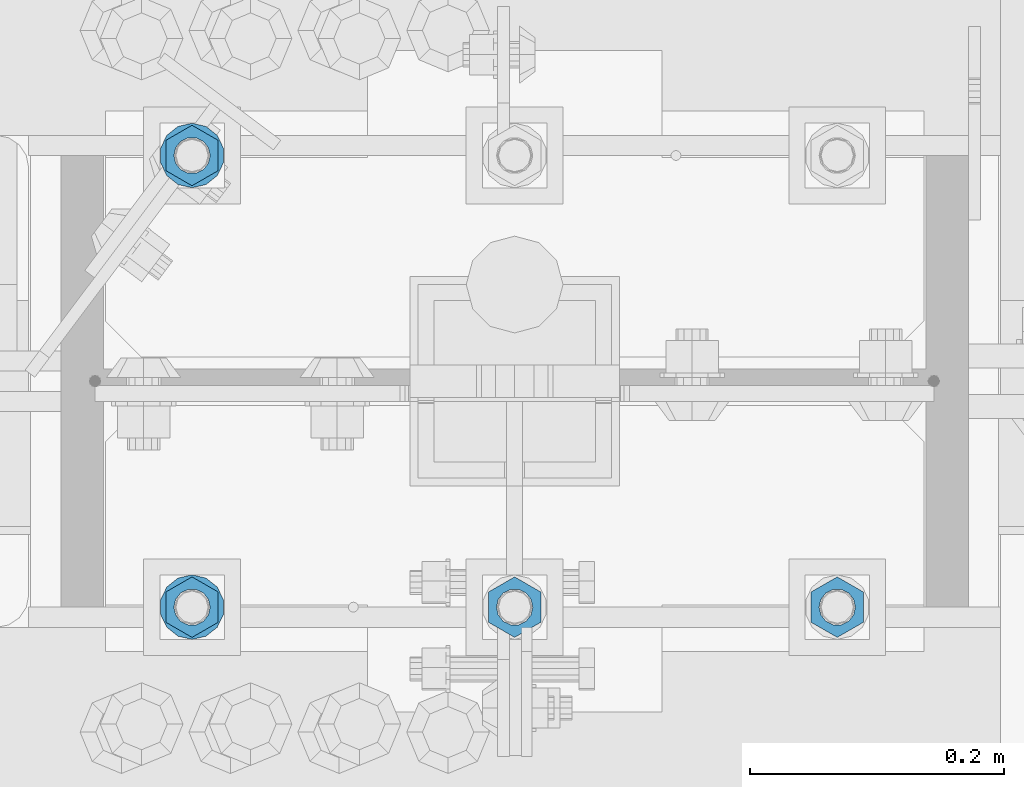
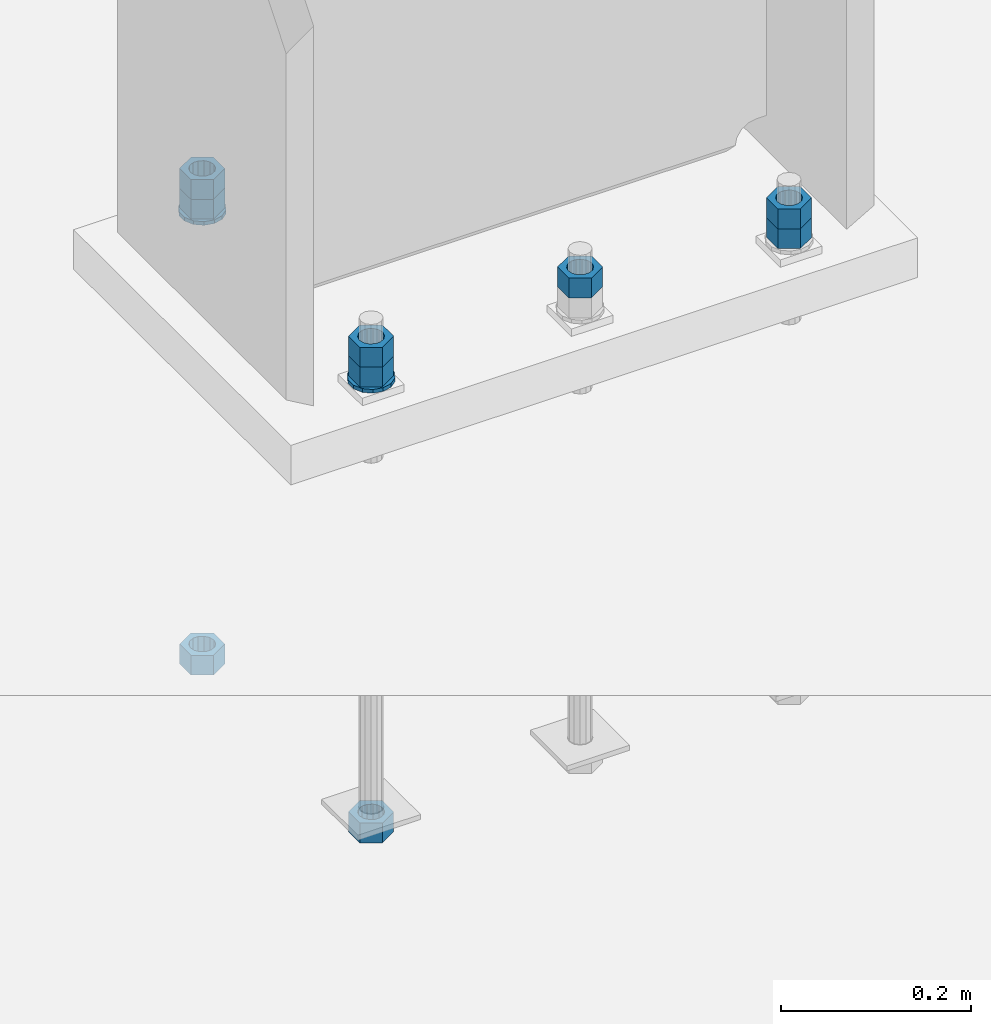
# One storey, part 1028 of 1763: 11 columns, 1 element without a shape of its own.
"""IFC2X3 building model written with IfcOpenShell, lengths in millimetres."""

from ifc_helpers import new_model, si_unit, frame, origin_with_axes, place, context, subcontext, project, spatial, faceted_brep, material, type_object, element, aggregate, save


model = new_model("IFC2X3")

# Units and contexts
model_context = context("Model", 3, precision=1e-05, world=origin_with_axes())
body_context = subcontext(model_context, "Body", "Model", "MODEL_VIEW")
ifc_project = project(units=[si_unit("LENGTHUNIT", "METRE", prefix="MILLI"), si_unit("AREAUNIT", "SQUARE_METRE"), si_unit("VOLUMEUNIT", "CUBIC_METRE"), si_unit("MASSUNIT", "GRAM", prefix="KILO"), si_unit("TIMEUNIT", "SECOND"), si_unit("PLANEANGLEUNIT", "RADIAN"), si_unit("SOLIDANGLEUNIT", "STERADIAN"), si_unit("THERMODYNAMICTEMPERATUREUNIT", "DEGREE_CELSIUS"), si_unit("LUMINOUSINTENSITYUNIT", "LUMEN")], contexts=[model_context])

# Site, building, storey
site_placement = place(None, origin_with_axes())
site = spatial("IfcSite", under=ifc_project, at=site_placement, CompositionType="ELEMENT")
building_placement = place(site_placement, origin_with_axes())
building = spatial("IfcBuilding", under=site, at=building_placement, Name="Undefined", CompositionType="ELEMENT")
storey_placement = place(building_placement, origin_with_axes())
storey = spatial("IfcBuildingStorey", under=building, at=storey_placement, Name="Undefined", CompositionType="ELEMENT", Elevation=0.0)

# Assembly, columns
assembly_placement = place(storey_placement, origin_with_axes())
assembly = element("IfcElementAssembly", 1, at=assembly_placement, inside=storey, Name="TEMPLATE", AssemblyPlace="NOTDEFINED", PredefinedType="RIGID_FRAME")
ifc_material_1 = material(Name="STEEL/A563")
column_type_1 = type_object("IfcColumnType", Name="1_HEAVY_HEX_NUT", PredefinedType="NOTDEFINED")
column_1_placement = place(assembly_placement, frame((-34695.8372736984, 51943.0, -150.812499999997), z_axis=(1.0, 0.0, 0.0), x_axis=(0.0, 0.0, -1.0)))
column_1 = element("IfcColumn", 2, at=column_1_placement, type_object=column_type_1, material=ifc_material_1, Name="NUT", ObjectType="1_HEAVY_HEX_NUT", context=body_context, shape_type="Brep", body=[
    faceted_brep([(0.0, -23.8099994659424, 0.0), (0.0, -11.9099998474121, -20.6200008392334), (25.4, -11.9099998474121, -20.6200008392334), (25.4, -23.8099994659424, 0.0), (0.0, 11.9099998474121, -20.6200008392334), (25.4, 11.9099998474121, -20.6200008392334), (0.0, 23.8099994659424, 0.0), (25.4, 23.8099994659424, 0.0), (0.0, 11.9099998474121, 20.6200008392334), (25.4, 11.9099998474121, 20.6200008392334), (0.0, -11.9099998474121, 20.6200008392334), (25.4, -11.9099998474121, 20.6200008392334), (0.0, 0.0, 14.289999961853), (0.0, 6.20019861543551, 12.8748450879575), (25.4, 6.20019861543551, 12.8748450879502), (25.4, 0.0, 14.289999961853), (0.0, 11.1723718546418, 8.90966924477834), (25.4, 11.1723718546418, 8.90966924477834), (0.0, 13.9317198278877, 3.17982413774735), (25.4, 13.9317198278877, 3.17982413774007), (0.0, 13.9317198278877, -3.17982413774735), (25.4, 13.9317198278877, -3.17982413774007), (0.0, 11.1723718546418, -8.90966924477834), (25.4, 11.1723718546418, -8.90966924477834), (0.0, 6.20019861543551, -12.8748450879575), (25.4, 6.20019861543551, -12.8748450879502), (0.0, 0.0, -14.289999961853), (25.4, 0.0, -14.289999961853), (0.0, -6.20019861543551, -12.8748450879575), (25.4, -6.20019861543551, -12.8748450879502), (0.0, -11.1723718546418, -8.90966924477834), (25.4, -11.1723718546418, -8.90966924477834), (0.0, -13.9317198278877, -3.17982413774735), (25.4, -13.9317198278877, -3.17982413774007), (0.0, -13.9317198278877, 3.17982413774735), (25.4, -13.9317198278877, 3.17982413774007), (0.0, -11.1723718546418, 8.90966924477834), (25.4, -11.1723718546418, 8.90966924477834), (0.0, -6.20019861543551, 12.8748450879575), (25.4, -6.20019861543551, 12.8748450879502)], [[[0, 1, 2, 3]], [[1, 4, 5, 2]], [[4, 6, 7, 5]], [[6, 8, 9, 7]], [[8, 10, 11, 9]], [[10, 0, 3, 11]], [[12, 13, 14, 15]], [[13, 16, 17, 14]], [[16, 18, 19, 17]], [[18, 20, 21, 19]], [[20, 22, 23, 21]], [[22, 24, 25, 23]], [[24, 26, 27, 25]], [[26, 28, 29, 27]], [[28, 30, 31, 29]], [[30, 32, 33, 31]], [[32, 34, 35, 33]], [[34, 36, 37, 35]], [[36, 38, 39, 37]], [[38, 12, 15, 39]], [[5, 7, 9, 11, 3, 2], [17, 19, 21, 23, 25, 27, 29, 31, 33, 35, 37, 39, 15, 14]], [[10, 8, 6, 4, 1, 0], [38, 36, 34, 32, 30, 28, 26, 24, 22, 20, 18, 16, 13, 12]]]),
])
column_2_placement = place(assembly_placement, frame((-34949.8372736984, 51943.0, -150.812499999997), z_axis=(1.0, 0.0, 0.0), x_axis=(0.0, 0.0, -1.0)))
column_2 = element("IfcColumn", 3, at=column_2_placement, type_object=column_type_1, material=ifc_material_1, Name="NUT", ObjectType="1_HEAVY_HEX_NUT", context=body_context, shape_type="Brep", body=[
    faceted_brep([(0.0, -23.8099994659424, 0.0), (0.0, -11.9099998474121, -20.6200008392334), (25.4, -11.9099998474121, -20.6200008392334), (25.4, -23.8099994659424, 0.0), (0.0, 11.9099998474121, -20.6200008392334), (25.4, 11.9099998474121, -20.6200008392334), (0.0, 23.8099994659424, 0.0), (25.4, 23.8099994659424, 0.0), (0.0, 11.9099998474121, 20.6200008392334), (25.4, 11.9099998474121, 20.6200008392334), (0.0, -11.9099998474121, 20.6200008392334), (25.4, -11.9099998474121, 20.6200008392334), (0.0, 0.0, 14.289999961853), (0.0, 6.20019861543551, 12.8748450879575), (25.4, 6.20019861543551, 12.8748450879502), (25.4, 0.0, 14.289999961853), (0.0, 11.1723718546418, 8.90966924477834), (25.4, 11.1723718546418, 8.90966924477834), (0.0, 13.9317198278877, 3.17982413774735), (25.4, 13.9317198278877, 3.17982413774007), (0.0, 13.9317198278877, -3.17982413774735), (25.4, 13.9317198278877, -3.17982413774007), (0.0, 11.1723718546418, -8.90966924477834), (25.4, 11.1723718546418, -8.90966924477834), (0.0, 6.20019861543551, -12.8748450879575), (25.4, 6.20019861543551, -12.8748450879502), (0.0, 0.0, -14.289999961853), (25.4, 0.0, -14.289999961853), (0.0, -6.20019861543551, -12.8748450879575), (25.4, -6.20019861543551, -12.8748450879502), (0.0, -11.1723718546418, -8.90966924477834), (25.4, -11.1723718546418, -8.90966924477834), (0.0, -13.9317198278877, -3.17982413774735), (25.4, -13.9317198278877, -3.17982413774007), (0.0, -13.9317198278877, 3.17982413774735), (25.4, -13.9317198278877, 3.17982413774007), (0.0, -11.1723718546418, 8.90966924477834), (25.4, -11.1723718546418, 8.90966924477834), (0.0, -6.20019861543551, 12.8748450879575), (25.4, -6.20019861543551, 12.8748450879502)], [[[0, 1, 2, 3]], [[1, 4, 5, 2]], [[4, 6, 7, 5]], [[6, 8, 9, 7]], [[8, 10, 11, 9]], [[10, 0, 3, 11]], [[12, 13, 14, 15]], [[13, 16, 17, 14]], [[16, 18, 19, 17]], [[18, 20, 21, 19]], [[20, 22, 23, 21]], [[22, 24, 25, 23]], [[24, 26, 27, 25]], [[26, 28, 29, 27]], [[28, 30, 31, 29]], [[30, 32, 33, 31]], [[32, 34, 35, 33]], [[34, 36, 37, 35]], [[36, 38, 39, 37]], [[38, 12, 15, 39]], [[5, 7, 9, 11, 3, 2], [17, 19, 21, 23, 25, 27, 29, 31, 33, 35, 37, 39, 15, 14]], [[10, 8, 6, 4, 1, 0], [38, 36, 34, 32, 30, 28, 26, 24, 22, 20, 18, 16, 13, 12]]]),
])
column_3_placement = place(assembly_placement, frame((-35203.8372736984, 51943.0, -150.812499999997), z_axis=(1.0, 0.0, 0.0), x_axis=(0.0, 0.0, -1.0)))
column_3 = element("IfcColumn", 4, at=column_3_placement, type_object=column_type_1, material=ifc_material_1, Name="NUT", ObjectType="1_HEAVY_HEX_NUT", context=body_context, shape_type="Brep", body=[
    faceted_brep([(0.0, -23.8099994659424, 0.0), (0.0, -11.9099998474121, -20.6200008392334), (25.4, -11.9099998474121, -20.6200008392334), (25.4, -23.8099994659424, 0.0), (0.0, 11.9099998474121, -20.6200008392334), (25.4, 11.9099998474121, -20.6200008392334), (0.0, 23.8099994659424, 0.0), (25.4, 23.8099994659424, 0.0), (0.0, 11.9099998474121, 20.6200008392334), (25.4, 11.9099998474121, 20.6200008392334), (0.0, -11.9099998474121, 20.6200008392334), (25.4, -11.9099998474121, 20.6200008392334), (0.0, 0.0, 14.289999961853), (0.0, 6.20019861543551, 12.8748450879575), (25.4, 6.20019861543551, 12.8748450879502), (25.4, 0.0, 14.289999961853), (0.0, 11.1723718546418, 8.90966924477834), (25.4, 11.1723718546418, 8.90966924477834), (0.0, 13.9317198278877, 3.17982413774735), (25.4, 13.9317198278877, 3.17982413774007), (0.0, 13.9317198278877, -3.17982413774735), (25.4, 13.9317198278877, -3.17982413774007), (0.0, 11.1723718546418, -8.90966924477834), (25.4, 11.1723718546418, -8.90966924477834), (0.0, 6.20019861543551, -12.8748450879575), (25.4, 6.20019861543551, -12.8748450879502), (0.0, 0.0, -14.289999961853), (25.4, 0.0, -14.289999961853), (0.0, -6.20019861543551, -12.8748450879575), (25.4, -6.20019861543551, -12.8748450879502), (0.0, -11.1723718546418, -8.90966924477834), (25.4, -11.1723718546418, -8.90966924477834), (0.0, -13.9317198278877, -3.17982413774735), (25.4, -13.9317198278877, -3.17982413774007), (0.0, -13.9317198278877, 3.17982413774735), (25.4, -13.9317198278877, 3.17982413774007), (0.0, -11.1723718546418, 8.90966924477834), (25.4, -11.1723718546418, 8.90966924477834), (0.0, -6.20019861543551, 12.8748450879575), (25.4, -6.20019861543551, 12.8748450879502)], [[[0, 1, 2, 3]], [[1, 4, 5, 2]], [[4, 6, 7, 5]], [[6, 8, 9, 7]], [[8, 10, 11, 9]], [[10, 0, 3, 11]], [[12, 13, 14, 15]], [[13, 16, 17, 14]], [[16, 18, 19, 17]], [[18, 20, 21, 19]], [[20, 22, 23, 21]], [[22, 24, 25, 23]], [[24, 26, 27, 25]], [[26, 28, 29, 27]], [[28, 30, 31, 29]], [[30, 32, 33, 31]], [[32, 34, 35, 33]], [[34, 36, 37, 35]], [[36, 38, 39, 37]], [[38, 12, 15, 39]], [[5, 7, 9, 11, 3, 2], [17, 19, 21, 23, 25, 27, 29, 31, 33, 35, 37, 39, 15, 14]], [[10, 8, 6, 4, 1, 0], [38, 36, 34, 32, 30, 28, 26, 24, 22, 20, 18, 16, 13, 12]]]),
])
column_4_placement = place(assembly_placement, frame((-35203.8372736984, 52298.6, -150.812499999997), z_axis=(-1.0, 0.0, 0.0), x_axis=(0.0, 0.0, -1.0)))
column_4 = element("IfcColumn", 5, at=column_4_placement, type_object=column_type_1, material=ifc_material_1, Name="NUT", ObjectType="1_HEAVY_HEX_NUT", context=body_context, shape_type="Brep", body=[
    faceted_brep([(0.0, -23.8099994659424, 0.0), (0.0, -11.9099998474121, -20.6200008392334), (25.4, -11.9099998474121, -20.6200008392334), (25.4, -23.8099994659424, 0.0), (0.0, 11.9099998474121, -20.6200008392334), (25.4, 11.9099998474121, -20.6200008392334), (0.0, 23.8099994659424, 0.0), (25.4, 23.8099994659424, 0.0), (0.0, 11.9099998474121, 20.6200008392334), (25.4, 11.9099998474121, 20.6200008392334), (0.0, -11.9099998474121, 20.6200008392334), (25.4, -11.9099998474121, 20.6200008392334), (0.0, 0.0, 14.289999961853), (0.0, 6.20019861543551, 12.8748450879575), (25.4, 6.20019861543551, 12.8748450879502), (25.4, 0.0, 14.289999961853), (0.0, 11.1723718546418, 8.90966924477834), (25.4, 11.1723718546418, 8.90966924477834), (0.0, 13.9317198278877, 3.17982413774735), (25.4, 13.9317198278877, 3.17982413774007), (0.0, 13.9317198278877, -3.17982413774735), (25.4, 13.9317198278877, -3.17982413774007), (0.0, 11.1723718546418, -8.90966924477834), (25.4, 11.1723718546418, -8.90966924477834), (0.0, 6.20019861543551, -12.8748450879575), (25.4, 6.20019861543551, -12.8748450879502), (0.0, 0.0, -14.289999961853), (25.4, 0.0, -14.289999961853), (0.0, -6.20019861543551, -12.8748450879575), (25.4, -6.20019861543551, -12.8748450879502), (0.0, -11.1723718546418, -8.90966924477834), (25.4, -11.1723718546418, -8.90966924477834), (0.0, -13.9317198278877, -3.17982413774735), (25.4, -13.9317198278877, -3.17982413774007), (0.0, -13.9317198278877, 3.17982413774735), (25.4, -13.9317198278877, 3.17982413774007), (0.0, -11.1723718546418, 8.90966924477834), (25.4, -11.1723718546418, 8.90966924477834), (0.0, -6.20019861543551, 12.8748450879575), (25.4, -6.20019861543551, 12.8748450879502)], [[[0, 1, 2, 3]], [[1, 4, 5, 2]], [[4, 6, 7, 5]], [[6, 8, 9, 7]], [[8, 10, 11, 9]], [[10, 0, 3, 11]], [[12, 13, 14, 15]], [[13, 16, 17, 14]], [[16, 18, 19, 17]], [[18, 20, 21, 19]], [[20, 22, 23, 21]], [[22, 24, 25, 23]], [[24, 26, 27, 25]], [[26, 28, 29, 27]], [[28, 30, 31, 29]], [[30, 32, 33, 31]], [[32, 34, 35, 33]], [[34, 36, 37, 35]], [[36, 38, 39, 37]], [[38, 12, 15, 39]], [[5, 7, 9, 11, 3, 2], [17, 19, 21, 23, 25, 27, 29, 31, 33, 35, 37, 39, 15, 14]], [[10, 8, 6, 4, 1, 0], [38, 36, 34, 32, 30, 28, 26, 24, 22, 20, 18, 16, 13, 12]]]),
])
column_5_placement = place(assembly_placement, frame((-34695.8372736984, 51943.0, -176.212499999997), z_axis=(1.0, 0.0, 0.0), x_axis=(0.0, 0.0, -1.0)))
column_5 = element("IfcColumn", 6, at=column_5_placement, type_object=column_type_1, material=ifc_material_1, Name="NUT", ObjectType="1_HEAVY_HEX_NUT", context=body_context, shape_type="Brep", body=[
    faceted_brep([(0.0, -23.8099994659424, 0.0), (0.0, -11.9099998474121, -20.6200008392334), (25.4, -11.9099998474121, -20.6200008392334), (25.4, -23.8099994659424, 0.0), (0.0, 11.9099998474121, -20.6200008392334), (25.4, 11.9099998474121, -20.6200008392334), (0.0, 23.8099994659424, 0.0), (25.4, 23.8099994659424, 0.0), (0.0, 11.9099998474121, 20.6200008392334), (25.4, 11.9099998474121, 20.6200008392334), (0.0, -11.9099998474121, 20.6200008392334), (25.4, -11.9099998474121, 20.6200008392334), (0.0, 0.0, 14.289999961853), (0.0, 6.20019861543551, 12.8748450879575), (25.4, 6.20019861543551, 12.8748450879502), (25.4, 0.0, 14.289999961853), (0.0, 11.1723718546418, 8.90966924477834), (25.4, 11.1723718546418, 8.90966924477834), (0.0, 13.9317198278877, 3.17982413774735), (25.4, 13.9317198278877, 3.17982413774007), (0.0, 13.9317198278877, -3.17982413774735), (25.4, 13.9317198278877, -3.17982413774007), (0.0, 11.1723718546418, -8.90966924477834), (25.4, 11.1723718546418, -8.90966924477834), (0.0, 6.20019861543551, -12.8748450879575), (25.4, 6.20019861543551, -12.8748450879502), (0.0, 0.0, -14.289999961853), (25.4, 0.0, -14.289999961853), (0.0, -6.20019861543551, -12.8748450879575), (25.4, -6.20019861543551, -12.8748450879502), (0.0, -11.1723718546418, -8.90966924477834), (25.4, -11.1723718546418, -8.90966924477834), (0.0, -13.9317198278877, -3.17982413774735), (25.4, -13.9317198278877, -3.17982413774007), (0.0, -13.9317198278877, 3.17982413774735), (25.4, -13.9317198278877, 3.17982413774007), (0.0, -11.1723718546418, 8.90966924477834), (25.4, -11.1723718546418, 8.90966924477834), (0.0, -6.20019861543551, 12.8748450879575), (25.4, -6.20019861543551, 12.8748450879502)], [[[0, 1, 2, 3]], [[1, 4, 5, 2]], [[4, 6, 7, 5]], [[6, 8, 9, 7]], [[8, 10, 11, 9]], [[10, 0, 3, 11]], [[12, 13, 14, 15]], [[13, 16, 17, 14]], [[16, 18, 19, 17]], [[18, 20, 21, 19]], [[20, 22, 23, 21]], [[22, 24, 25, 23]], [[24, 26, 27, 25]], [[26, 28, 29, 27]], [[28, 30, 31, 29]], [[30, 32, 33, 31]], [[32, 34, 35, 33]], [[34, 36, 37, 35]], [[36, 38, 39, 37]], [[38, 12, 15, 39]], [[5, 7, 9, 11, 3, 2], [17, 19, 21, 23, 25, 27, 29, 31, 33, 35, 37, 39, 15, 14]], [[10, 8, 6, 4, 1, 0], [38, 36, 34, 32, 30, 28, 26, 24, 22, 20, 18, 16, 13, 12]]]),
])
column_6_placement = place(assembly_placement, frame((-35203.8372736984, 51943.0, -176.212499999997), z_axis=(1.0, 0.0, 0.0), x_axis=(0.0, 0.0, -1.0)))
column_6 = element("IfcColumn", 7, at=column_6_placement, type_object=column_type_1, material=ifc_material_1, Name="NUT", ObjectType="1_HEAVY_HEX_NUT", context=body_context, shape_type="Brep", body=[
    faceted_brep([(0.0, -23.8099994659424, 0.0), (0.0, -11.9099998474121, -20.6200008392334), (25.4, -11.9099998474121, -20.6200008392334), (25.4, -23.8099994659424, 0.0), (0.0, 11.9099998474121, -20.6200008392334), (25.4, 11.9099998474121, -20.6200008392334), (0.0, 23.8099994659424, 0.0), (25.4, 23.8099994659424, 0.0), (0.0, 11.9099998474121, 20.6200008392334), (25.4, 11.9099998474121, 20.6200008392334), (0.0, -11.9099998474121, 20.6200008392334), (25.4, -11.9099998474121, 20.6200008392334), (0.0, 0.0, 14.289999961853), (0.0, 6.20019861543551, 12.8748450879575), (25.4, 6.20019861543551, 12.8748450879502), (25.4, 0.0, 14.289999961853), (0.0, 11.1723718546418, 8.90966924477834), (25.4, 11.1723718546418, 8.90966924477834), (0.0, 13.9317198278877, 3.17982413774735), (25.4, 13.9317198278877, 3.17982413774007), (0.0, 13.9317198278877, -3.17982413774735), (25.4, 13.9317198278877, -3.17982413774007), (0.0, 11.1723718546418, -8.90966924477834), (25.4, 11.1723718546418, -8.90966924477834), (0.0, 6.20019861543551, -12.8748450879575), (25.4, 6.20019861543551, -12.8748450879502), (0.0, 0.0, -14.289999961853), (25.4, 0.0, -14.289999961853), (0.0, -6.20019861543551, -12.8748450879575), (25.4, -6.20019861543551, -12.8748450879502), (0.0, -11.1723718546418, -8.90966924477834), (25.4, -11.1723718546418, -8.90966924477834), (0.0, -13.9317198278877, -3.17982413774735), (25.4, -13.9317198278877, -3.17982413774007), (0.0, -13.9317198278877, 3.17982413774735), (25.4, -13.9317198278877, 3.17982413774007), (0.0, -11.1723718546418, 8.90966924477834), (25.4, -11.1723718546418, 8.90966924477834), (0.0, -6.20019861543551, 12.8748450879575), (25.4, -6.20019861543551, 12.8748450879502)], [[[0, 1, 2, 3]], [[1, 4, 5, 2]], [[4, 6, 7, 5]], [[6, 8, 9, 7]], [[8, 10, 11, 9]], [[10, 0, 3, 11]], [[12, 13, 14, 15]], [[13, 16, 17, 14]], [[16, 18, 19, 17]], [[18, 20, 21, 19]], [[20, 22, 23, 21]], [[22, 24, 25, 23]], [[24, 26, 27, 25]], [[26, 28, 29, 27]], [[28, 30, 31, 29]], [[30, 32, 33, 31]], [[32, 34, 35, 33]], [[34, 36, 37, 35]], [[36, 38, 39, 37]], [[38, 12, 15, 39]], [[5, 7, 9, 11, 3, 2], [17, 19, 21, 23, 25, 27, 29, 31, 33, 35, 37, 39, 15, 14]], [[10, 8, 6, 4, 1, 0], [38, 36, 34, 32, 30, 28, 26, 24, 22, 20, 18, 16, 13, 12]]]),
])
column_7_placement = place(assembly_placement, frame((-35203.8372736984, 51943.0, -761.999999999998), z_axis=(1.0, 0.0, 0.0), x_axis=(0.0, 0.0, -1.0)))
column_7 = element("IfcColumn", 8, at=column_7_placement, type_object=column_type_1, material=ifc_material_1, Name="NUT", ObjectType="1_HEAVY_HEX_NUT", context=body_context, shape_type="Brep", body=[
    faceted_brep([(0.0, -23.8099994659424, 0.0), (0.0, -11.9099998474121, -20.6200008392334), (25.4, -11.9099998474121, -20.6200008392334), (25.4, -23.8099994659424, 0.0), (0.0, 11.9099998474121, -20.6200008392334), (25.4, 11.9099998474121, -20.6200008392334), (0.0, 23.8099994659424, 0.0), (25.4, 23.8099994659424, 0.0), (0.0, 11.9099998474121, 20.6200008392334), (25.4, 11.9099998474121, 20.6200008392334), (0.0, -11.9099998474121, 20.6200008392334), (25.4, -11.9099998474121, 20.6200008392334), (0.0, 0.0, 14.289999961853), (0.0, 6.20019861543551, 12.8748450879575), (25.4, 6.20019861543551, 12.8748450879502), (25.4, 0.0, 14.289999961853), (0.0, 11.1723718546418, 8.90966924477834), (25.4, 11.1723718546418, 8.90966924477834), (0.0, 13.9317198278877, 3.17982413774735), (25.4, 13.9317198278877, 3.17982413774007), (0.0, 13.9317198278877, -3.17982413774735), (25.4, 13.9317198278877, -3.17982413774007), (0.0, 11.1723718546418, -8.90966924477834), (25.4, 11.1723718546418, -8.90966924477834), (0.0, 6.20019861543551, -12.8748450879575), (25.4, 6.20019861543551, -12.8748450879502), (0.0, 0.0, -14.289999961853), (25.4, 0.0, -14.289999961853), (0.0, -6.20019861543551, -12.8748450879575), (25.4, -6.20019861543551, -12.8748450879502), (0.0, -11.1723718546418, -8.90966924477834), (25.4, -11.1723718546418, -8.90966924477834), (0.0, -13.9317198278877, -3.17982413774735), (25.4, -13.9317198278877, -3.17982413774007), (0.0, -13.9317198278877, 3.17982413774735), (25.4, -13.9317198278877, 3.17982413774007), (0.0, -11.1723718546418, 8.90966924477834), (25.4, -11.1723718546418, 8.90966924477834), (0.0, -6.20019861543551, 12.8748450879575), (25.4, -6.20019861543551, 12.8748450879502)], [[[0, 1, 2, 3]], [[1, 4, 5, 2]], [[4, 6, 7, 5]], [[6, 8, 9, 7]], [[8, 10, 11, 9]], [[10, 0, 3, 11]], [[12, 13, 14, 15]], [[13, 16, 17, 14]], [[16, 18, 19, 17]], [[18, 20, 21, 19]], [[20, 22, 23, 21]], [[22, 24, 25, 23]], [[24, 26, 27, 25]], [[26, 28, 29, 27]], [[28, 30, 31, 29]], [[30, 32, 33, 31]], [[32, 34, 35, 33]], [[34, 36, 37, 35]], [[36, 38, 39, 37]], [[38, 12, 15, 39]], [[5, 7, 9, 11, 3, 2], [17, 19, 21, 23, 25, 27, 29, 31, 33, 35, 37, 39, 15, 14]], [[10, 8, 6, 4, 1, 0], [38, 36, 34, 32, 30, 28, 26, 24, 22, 20, 18, 16, 13, 12]]]),
])
column_8_placement = place(assembly_placement, frame((-35203.8372736984, 52298.6, -176.212499999997), z_axis=(-1.0, 0.0, 0.0), x_axis=(0.0, 0.0, -1.0)))
column_8 = element("IfcColumn", 9, at=column_8_placement, type_object=column_type_1, material=ifc_material_1, Name="NUT", ObjectType="1_HEAVY_HEX_NUT", context=body_context, shape_type="Brep", body=[
    faceted_brep([(0.0, -23.8099994659424, 0.0), (0.0, -11.9099998474121, -20.6200008392334), (25.4, -11.9099998474121, -20.6200008392334), (25.4, -23.8099994659424, 0.0), (0.0, 11.9099998474121, -20.6200008392334), (25.4, 11.9099998474121, -20.6200008392334), (0.0, 23.8099994659424, 0.0), (25.4, 23.8099994659424, 0.0), (0.0, 11.9099998474121, 20.6200008392334), (25.4, 11.9099998474121, 20.6200008392334), (0.0, -11.9099998474121, 20.6200008392334), (25.4, -11.9099998474121, 20.6200008392334), (0.0, 0.0, 14.289999961853), (0.0, 6.20019861543551, 12.8748450879575), (25.4, 6.20019861543551, 12.8748450879502), (25.4, 0.0, 14.289999961853), (0.0, 11.1723718546418, 8.90966924477834), (25.4, 11.1723718546418, 8.90966924477834), (0.0, 13.9317198278877, 3.17982413774735), (25.4, 13.9317198278877, 3.17982413774007), (0.0, 13.9317198278877, -3.17982413774735), (25.4, 13.9317198278877, -3.17982413774007), (0.0, 11.1723718546418, -8.90966924477834), (25.4, 11.1723718546418, -8.90966924477834), (0.0, 6.20019861543551, -12.8748450879575), (25.4, 6.20019861543551, -12.8748450879502), (0.0, 0.0, -14.289999961853), (25.4, 0.0, -14.289999961853), (0.0, -6.20019861543551, -12.8748450879575), (25.4, -6.20019861543551, -12.8748450879502), (0.0, -11.1723718546418, -8.90966924477834), (25.4, -11.1723718546418, -8.90966924477834), (0.0, -13.9317198278877, -3.17982413774735), (25.4, -13.9317198278877, -3.17982413774007), (0.0, -13.9317198278877, 3.17982413774735), (25.4, -13.9317198278877, 3.17982413774007), (0.0, -11.1723718546418, 8.90966924477834), (25.4, -11.1723718546418, 8.90966924477834), (0.0, -6.20019861543551, 12.8748450879575), (25.4, -6.20019861543551, 12.8748450879502)], [[[0, 1, 2, 3]], [[1, 4, 5, 2]], [[4, 6, 7, 5]], [[6, 8, 9, 7]], [[8, 10, 11, 9]], [[10, 0, 3, 11]], [[12, 13, 14, 15]], [[13, 16, 17, 14]], [[16, 18, 19, 17]], [[18, 20, 21, 19]], [[20, 22, 23, 21]], [[22, 24, 25, 23]], [[24, 26, 27, 25]], [[26, 28, 29, 27]], [[28, 30, 31, 29]], [[30, 32, 33, 31]], [[32, 34, 35, 33]], [[34, 36, 37, 35]], [[36, 38, 39, 37]], [[38, 12, 15, 39]], [[5, 7, 9, 11, 3, 2], [17, 19, 21, 23, 25, 27, 29, 31, 33, 35, 37, 39, 15, 14]], [[10, 8, 6, 4, 1, 0], [38, 36, 34, 32, 30, 28, 26, 24, 22, 20, 18, 16, 13, 12]]]),
])
column_9_placement = place(assembly_placement, frame((-35203.8372736984, 52298.6, -761.999999999998), z_axis=(-1.0, 0.0, 0.0), x_axis=(0.0, 0.0, -1.0)))
column_9 = element("IfcColumn", 10, at=column_9_placement, type_object=column_type_1, material=ifc_material_1, Name="NUT", ObjectType="1_HEAVY_HEX_NUT", context=body_context, shape_type="Brep", body=[
    faceted_brep([(0.0, -23.8099994659424, 0.0), (0.0, -11.9099998474121, -20.6200008392334), (25.4, -11.9099998474121, -20.6200008392334), (25.4, -23.8099994659424, 0.0), (0.0, 11.9099998474121, -20.6200008392334), (25.4, 11.9099998474121, -20.6200008392334), (0.0, 23.8099994659424, 0.0), (25.4, 23.8099994659424, 0.0), (0.0, 11.9099998474121, 20.6200008392334), (25.4, 11.9099998474121, 20.6200008392334), (0.0, -11.9099998474121, 20.6200008392334), (25.4, -11.9099998474121, 20.6200008392334), (0.0, 0.0, 14.289999961853), (0.0, 6.20019861543551, 12.8748450879575), (25.4, 6.20019861543551, 12.8748450879502), (25.4, 0.0, 14.289999961853), (0.0, 11.1723718546418, 8.90966924477834), (25.4, 11.1723718546418, 8.90966924477834), (0.0, 13.9317198278877, 3.17982413774735), (25.4, 13.9317198278877, 3.17982413774007), (0.0, 13.9317198278877, -3.17982413774735), (25.4, 13.9317198278877, -3.17982413774007), (0.0, 11.1723718546418, -8.90966924477834), (25.4, 11.1723718546418, -8.90966924477834), (0.0, 6.20019861543551, -12.8748450879575), (25.4, 6.20019861543551, -12.8748450879502), (0.0, 0.0, -14.289999961853), (25.4, 0.0, -14.289999961853), (0.0, -6.20019861543551, -12.8748450879575), (25.4, -6.20019861543551, -12.8748450879502), (0.0, -11.1723718546418, -8.90966924477834), (25.4, -11.1723718546418, -8.90966924477834), (0.0, -13.9317198278877, -3.17982413774735), (25.4, -13.9317198278877, -3.17982413774007), (0.0, -13.9317198278877, 3.17982413774735), (25.4, -13.9317198278877, 3.17982413774007), (0.0, -11.1723718546418, 8.90966924477834), (25.4, -11.1723718546418, 8.90966924477834), (0.0, -6.20019861543551, 12.8748450879575), (25.4, -6.20019861543551, 12.8748450879502)], [[[0, 1, 2, 3]], [[1, 4, 5, 2]], [[4, 6, 7, 5]], [[6, 8, 9, 7]], [[8, 10, 11, 9]], [[10, 0, 3, 11]], [[12, 13, 14, 15]], [[13, 16, 17, 14]], [[16, 18, 19, 17]], [[18, 20, 21, 19]], [[20, 22, 23, 21]], [[22, 24, 25, 23]], [[24, 26, 27, 25]], [[26, 28, 29, 27]], [[28, 30, 31, 29]], [[30, 32, 33, 31]], [[32, 34, 35, 33]], [[34, 36, 37, 35]], [[36, 38, 39, 37]], [[38, 12, 15, 39]], [[5, 7, 9, 11, 3, 2], [17, 19, 21, 23, 25, 27, 29, 31, 33, 35, 37, 39, 15, 14]], [[10, 8, 6, 4, 1, 0], [38, 36, 34, 32, 30, 28, 26, 24, 22, 20, 18, 16, 13, 12]]]),
])
ifc_material_2 = material(Name="STEEL/F436")
column_type_2 = type_object("IfcColumnType", Name="1_WASHER", PredefinedType="NOTDEFINED")
column_10_placement = place(assembly_placement, frame((-35203.8372736984, 51943.0, -201.612499999997), z_axis=(1.0, 0.0, 0.0), x_axis=(0.0, 0.0, -1.0)))
column_10 = element("IfcColumn", 11, at=column_10_placement, type_object=column_type_2, material=ifc_material_2, Name="WASHER", ObjectType="1_WASHER", context=body_context, shape_type="Brep", body=[
    faceted_brep([(0.0, -25.4000000000015, 0.0), (0.0, -22.8846089010258, -11.0206468080723), (4.76249999999982, -22.8846089010258, -11.0206468080723), (4.76249999999982, -25.3999996185303, 0.0), (0.0, -15.8366407293724, -19.8585193564359), (4.76249999999982, -15.8366407293724, -19.8585193564359), (0.0, -5.65203163760452, -24.7631685975066), (4.76249999999982, -5.65203163760452, -24.7631685975066), (0.0, 5.65203163760452, -24.7631685975066), (4.76249999999982, 5.65203163760452, -24.7631685975066), (0.0, 15.8366407293724, -19.8585193564359), (4.76249999999982, 15.8366407293724, -19.8585193564359), (0.0, 22.8846089010258, -11.0206468080723), (4.76249999999982, 22.8846089010258, -11.0206468080723), (0.0, 25.4000000000015, 0.0), (4.76249999999982, 25.3999996185303, 0.0), (0.0, 22.8846089010258, 11.0206468080723), (4.76249999999982, 22.8846089010258, 11.0206468080723), (0.0, 15.8366407293724, 19.8585193564359), (4.76249999999982, 15.8366407293724, 19.8585193564359), (0.0, 5.65203163760452, 24.7631685975066), (4.76249999999982, 5.65203163760452, 24.7631685975066), (0.0, -5.65203163760452, 24.7631685975066), (4.76249999999982, -5.65203163760452, 24.7631685975066), (0.0, -15.8366407293724, 19.8585193564359), (4.76249999999982, -15.8366407293724, 19.8585193564359), (0.0, -22.8846089010258, 11.0206468080723), (4.76249999999982, -22.8846089010258, 11.0206468080723), (0.0, 0.0, 14.289999961853), (0.0, 6.20019861543551, 12.8748450879575), (4.76249999999982, 6.20019861543551, 12.8748450879502), (4.76249999999982, 0.0, 14.289999961853), (0.0, 11.1723718546418, 8.90966924477834), (4.76249999999982, 11.1723718546418, 8.90966924477834), (0.0, 13.9317198278877, 3.17982413774735), (4.76249999999982, 13.9317198278877, 3.17982413774007), (0.0, 13.9317198278877, -3.17982413774735), (4.76249999999982, 13.9317198278877, -3.17982413774007), (0.0, 11.1723718546418, -8.90966924477834), (4.76249999999982, 11.1723718546418, -8.90966924477834), (0.0, 6.20019861543551, -12.8748450879575), (4.76249999999982, 6.20019861543551, -12.8748450879502), (0.0, 0.0, -14.289999961853), (4.76249999999982, 0.0, -14.289999961853), (0.0, -6.20019861543551, -12.8748450879575), (4.76249999999982, -6.20019861543551, -12.8748450879502), (0.0, -11.1723718546418, -8.90966924477834), (4.76249999999982, -11.1723718546418, -8.90966924477834), (0.0, -13.9317198278877, -3.17982413774735), (4.76249999999982, -13.9317198278877, -3.17982413774007), (0.0, -13.9317198278877, 3.17982413774735), (4.76249999999982, -13.9317198278877, 3.17982413774007), (0.0, -11.1723718546418, 8.90966924477834), (4.76249999999982, -11.1723718546418, 8.90966924477834), (0.0, -6.20019861543551, 12.8748450879575), (4.76249999999982, -6.20019861543551, 12.8748450879502)], [[[0, 1, 2, 3]], [[1, 4, 5, 2]], [[4, 6, 7, 5]], [[6, 8, 9, 7]], [[8, 10, 11, 9]], [[10, 12, 13, 11]], [[12, 14, 15, 13]], [[14, 16, 17, 15]], [[16, 18, 19, 17]], [[18, 20, 21, 19]], [[20, 22, 23, 21]], [[22, 24, 25, 23]], [[24, 26, 27, 25]], [[26, 0, 3, 27]], [[28, 29, 30, 31]], [[29, 32, 33, 30]], [[32, 34, 35, 33]], [[34, 36, 37, 35]], [[36, 38, 39, 37]], [[38, 40, 41, 39]], [[40, 42, 43, 41]], [[42, 44, 45, 43]], [[44, 46, 47, 45]], [[46, 48, 49, 47]], [[48, 50, 51, 49]], [[50, 52, 53, 51]], [[52, 54, 55, 53]], [[54, 28, 31, 55]], [[5, 7, 9, 11, 13, 15, 17, 19, 21, 23, 25, 27, 3, 2], [33, 35, 37, 39, 41, 43, 45, 47, 49, 51, 53, 55, 31, 30]], [[26, 24, 22, 20, 18, 16, 14, 12, 10, 8, 6, 4, 1, 0], [54, 52, 50, 48, 46, 44, 42, 40, 38, 36, 34, 32, 29, 28]]]),
])
column_11_placement = place(assembly_placement, frame((-35203.8372736984, 52298.6, -201.612499999997), z_axis=(-1.0, 0.0, 0.0), x_axis=(0.0, 0.0, -1.0)))
column_11 = element("IfcColumn", 12, at=column_11_placement, type_object=column_type_2, material=ifc_material_2, Name="WASHER", ObjectType="1_WASHER", context=body_context, shape_type="Brep", body=[
    faceted_brep([(0.0, -25.4000000000015, 0.0), (0.0, -22.8846089010258, -11.0206468080723), (4.76249999999982, -22.8846089010258, -11.0206468080723), (4.76249999999982, -25.3999996185303, 0.0), (0.0, -15.8366407293724, -19.8585193564359), (4.76249999999982, -15.8366407293724, -19.8585193564359), (0.0, -5.65203163760452, -24.7631685975066), (4.76249999999982, -5.65203163760452, -24.7631685975066), (0.0, 5.65203163760452, -24.7631685975066), (4.76249999999982, 5.65203163760452, -24.7631685975066), (0.0, 15.8366407293724, -19.8585193564359), (4.76249999999982, 15.8366407293724, -19.8585193564359), (0.0, 22.8846089010258, -11.0206468080723), (4.76249999999982, 22.8846089010258, -11.0206468080723), (0.0, 25.4000000000015, 0.0), (4.76249999999982, 25.3999996185303, 0.0), (0.0, 22.8846089010258, 11.0206468080723), (4.76249999999982, 22.8846089010258, 11.0206468080723), (0.0, 15.8366407293724, 19.8585193564359), (4.76249999999982, 15.8366407293724, 19.8585193564359), (0.0, 5.65203163760452, 24.7631685975066), (4.76249999999982, 5.65203163760452, 24.7631685975066), (0.0, -5.65203163760452, 24.7631685975066), (4.76249999999982, -5.65203163760452, 24.7631685975066), (0.0, -15.8366407293724, 19.8585193564359), (4.76249999999982, -15.8366407293724, 19.8585193564359), (0.0, -22.8846089010258, 11.0206468080723), (4.76249999999982, -22.8846089010258, 11.0206468080723), (0.0, 0.0, 14.289999961853), (0.0, 6.20019861543551, 12.8748450879575), (4.76249999999982, 6.20019861543551, 12.8748450879502), (4.76249999999982, 0.0, 14.289999961853), (0.0, 11.1723718546418, 8.90966924477834), (4.76249999999982, 11.1723718546418, 8.90966924477834), (0.0, 13.9317198278877, 3.17982413774735), (4.76249999999982, 13.9317198278877, 3.17982413774007), (0.0, 13.9317198278877, -3.17982413774735), (4.76249999999982, 13.9317198278877, -3.17982413774007), (0.0, 11.1723718546418, -8.90966924477834), (4.76249999999982, 11.1723718546418, -8.90966924477834), (0.0, 6.20019861543551, -12.8748450879575), (4.76249999999982, 6.20019861543551, -12.8748450879502), (0.0, 0.0, -14.289999961853), (4.76249999999982, 0.0, -14.289999961853), (0.0, -6.20019861543551, -12.8748450879575), (4.76249999999982, -6.20019861543551, -12.8748450879502), (0.0, -11.1723718546418, -8.90966924477834), (4.76249999999982, -11.1723718546418, -8.90966924477834), (0.0, -13.9317198278877, -3.17982413774735), (4.76249999999982, -13.9317198278877, -3.17982413774007), (0.0, -13.9317198278877, 3.17982413774735), (4.76249999999982, -13.9317198278877, 3.17982413774007), (0.0, -11.1723718546418, 8.90966924477834), (4.76249999999982, -11.1723718546418, 8.90966924477834), (0.0, -6.20019861543551, 12.8748450879575), (4.76249999999982, -6.20019861543551, 12.8748450879502)], [[[0, 1, 2, 3]], [[1, 4, 5, 2]], [[4, 6, 7, 5]], [[6, 8, 9, 7]], [[8, 10, 11, 9]], [[10, 12, 13, 11]], [[12, 14, 15, 13]], [[14, 16, 17, 15]], [[16, 18, 19, 17]], [[18, 20, 21, 19]], [[20, 22, 23, 21]], [[22, 24, 25, 23]], [[24, 26, 27, 25]], [[26, 0, 3, 27]], [[28, 29, 30, 31]], [[29, 32, 33, 30]], [[32, 34, 35, 33]], [[34, 36, 37, 35]], [[36, 38, 39, 37]], [[38, 40, 41, 39]], [[40, 42, 43, 41]], [[42, 44, 45, 43]], [[44, 46, 47, 45]], [[46, 48, 49, 47]], [[48, 50, 51, 49]], [[50, 52, 53, 51]], [[52, 54, 55, 53]], [[54, 28, 31, 55]], [[5, 7, 9, 11, 13, 15, 17, 19, 21, 23, 25, 27, 3, 2], [33, 35, 37, 39, 41, 43, 45, 47, 49, 51, 53, 55, 31, 30]], [[26, 24, 22, 20, 18, 16, 14, 12, 10, 8, 6, 4, 1, 0], [54, 52, 50, 48, 46, 44, 42, 40, 38, 36, 34, 32, 29, 28]]]),
])
aggregate(assembly, [column_1, column_2, column_3, column_4, column_5, column_6, column_10, column_7, column_8, column_11, column_9])

save(model, "model.ifc")
